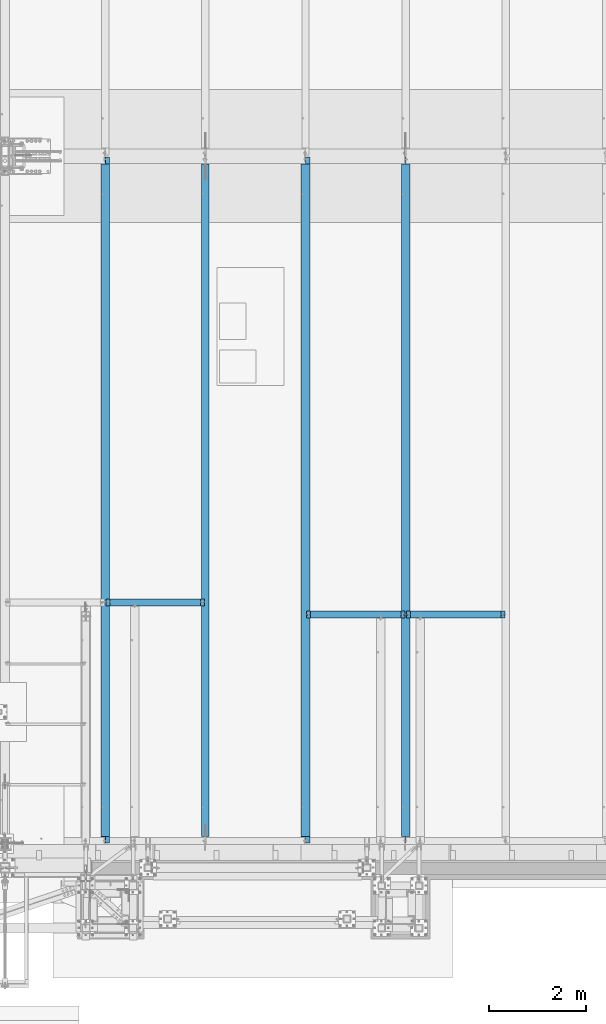
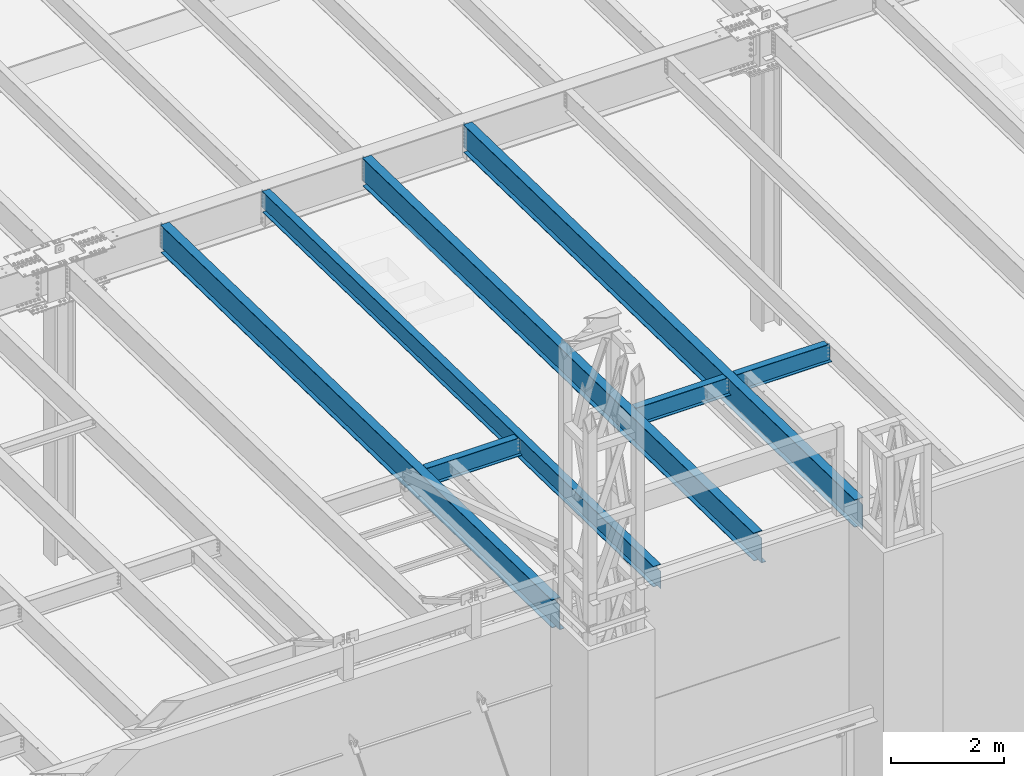
# One storey, part 1066 of 1763: 7 beams, 7 elements without a shape of their own.
"""IFC2X3 building model written with IfcOpenShell, lengths in millimetres."""

import ifcopenshell
import ifcopenshell.guid

model = None  # the IFC model being written
_history = None  # IfcOwnerHistory: only IFC2X3 demands one
_inside = {}  # id of a spatial element -> (the spatial element, [elements in it])
_under = {}  # id of a project, library or spatial element -> (it, [spatial elements below it])
_declared = {}  # id of a project -> (the project, [libraries it declares])
_typed = {}  # id of a type object -> (the type object, [elements of that type])
_made_of = {}  # id of a material, layer set ... -> (it, [elements and type objects made of it])


def new_model(schema):
    """Start an empty IFC model of exactly this schema.

    Asked for "IFC4X3", IfcOpenShell would pick the latest addendum, in which some entities
    have other attributes; the version numbers below select the first issue.
    IFC2X3 requires an IfcOwnerHistory on every rooted entity: one is made here for all.
    """
    global model, _history
    if schema == "IFC4X3":
        model = ifcopenshell.file(schema_version=(4, 3, 0, 0))
    else:
        model = ifcopenshell.file(schema=schema)
    _inside.clear()
    _under.clear()
    _declared.clear()
    _typed.clear()
    _made_of.clear()
    _history = None
    if model.schema == "IFC2X3":
        org = make("IfcOrganization", Name="unknown")
        user = make(
            "IfcPersonAndOrganization",
            ThePerson=make("IfcPerson", FamilyName="unknown"),
            TheOrganization=org,
        )
        app = make(
            "IfcApplication",
            ApplicationDeveloper=org,
            Version="unknown",
            ApplicationFullName="unknown",
            ApplicationIdentifier="unknown",
        )
        _history = make(
            "IfcOwnerHistory",
            OwningUser=user,
            OwningApplication=app,
            ChangeAction="ADDED",
            CreationDate=0,
        )
    return model


def make(cls, **values):
    """One entity of the class cls with the attributes given. An attribute that is None is left unset."""
    return model.create_entity(
        cls, **{name: value for name, value in values.items() if value is not None}
    )


def rooted(cls, **values):
    """An entity with a GlobalId (a new one), such as an element, a storey or a relation."""
    return make(cls, GlobalId=ifcopenshell.guid.new(), OwnerHistory=_history, **values)


def si_unit(unit_type, name, prefix=None):
    """IfcSIUnit, for example si_unit("LENGTHUNIT", "METRE", prefix="MILLI")."""
    return make("IfcSIUnit", UnitType=unit_type, Prefix=prefix, Name=name)


def assignment(units):
    """IfcUnitAssignment: the units of a project."""
    return None if units is None else make("IfcUnitAssignment", Units=units)


def point(xyz):
    """IfcCartesianPoint."""
    return None if xyz is None else make("IfcCartesianPoint", Coordinates=xyz)


def direction(xyz):
    """IfcDirection."""
    return None if xyz is None else make("IfcDirection", DirectionRatios=xyz)


def frame(location, z_axis=None, x_axis=None):
    """IfcAxis2Placement3D, a coordinate frame: its origin and axes. An axis left out is left unset."""
    return make(
        "IfcAxis2Placement3D",
        Location=point(location),
        Axis=direction(z_axis),
        RefDirection=direction(x_axis),
    )


def origin_with_axes():
    """The frame at (0, 0, 0) with the z axis (0, 0, 1) and the x axis (1, 0, 0) written out."""
    return frame((0.0, 0.0, 0.0), z_axis=(0.0, 0.0, 1.0), x_axis=(1.0, 0.0, 0.0))


def place(relative_to, where):
    """IfcLocalPlacement: puts the frame where relative to a parent placement (None: the world)."""
    return make(
        "IfcLocalPlacement", PlacementRelTo=relative_to, RelativePlacement=where
    )


def context(
    kind, dimensions, precision=None, world=None, true_north=None, identifier=None
):
    """IfcGeometricRepresentationContext, for example the 3D "Model" context."""
    return make(
        "IfcGeometricRepresentationContext",
        ContextIdentifier=identifier,
        ContextType=kind,
        CoordinateSpaceDimension=dimensions,
        Precision=precision,
        WorldCoordinateSystem=world,
        TrueNorth=true_north,
    )


def subcontext(parent, identifier, kind, view, scale=None):
    """IfcGeometricRepresentationSubContext, for example "Body" below "Model"."""
    return make(
        "IfcGeometricRepresentationSubContext",
        ContextIdentifier=identifier,
        ContextType=kind,
        ParentContext=parent,
        TargetScale=scale,
        TargetView=view,
    )


def project(units=None, contexts=None):
    """IfcProject with its units and contexts."""
    return rooted(
        "IfcProject",
        Name="project",
        RepresentationContexts=contexts,
        UnitsInContext=assignment(units),
    )


def spatial(cls, under=None, at=None, **own):
    """A site, building, storey or space (cls), placed at a placement, below another one or the project."""
    s = rooted(cls, ObjectPlacement=at, **own)
    if under is not None:
        _under.setdefault(under.id(), (under, []))[1].append(s)
    return s


def faces_of(points, faces, orient=None, outer=None):
    """IfcFace entities. A face is a list of loops; a loop is a list of indices into points, from 0.

    orient and outer hold one flag for each loop. By default every Orientation is true, the
    first loop of a face is its IfcFaceOuterBound and the others are IfcFaceBound.
    """
    made = []
    for i, loops in enumerate(faces):
        bounds = []
        for j, loop in enumerate(loops):
            is_outer = j == 0 if outer is None else outer[i][j]
            bounds.append(
                make(
                    "IfcFaceOuterBound" if is_outer else "IfcFaceBound",
                    Bound=make("IfcPolyLoop", Polygon=[points[k] for k in loop]),
                    Orientation=True if orient is None else orient[i][j],
                )
            )
        made.append(make("IfcFace", Bounds=bounds))
    return made


def faceted_brep(points, faces, orient=None, outer=None, voids=None):
    """IfcFacetedBrep: a solid bounded by flat faces; with voids (closed shells), ...WithVoids."""
    shared = [point(p) for p in points]
    hull = make("IfcClosedShell", CfsFaces=faces_of(shared, faces, orient, outer))
    if voids is None:
        return make("IfcFacetedBrep", Outer=hull)
    return make(
        "IfcFacetedBrepWithVoids",
        Outer=hull,
        Voids=[
            make(cls, CfsFaces=faces_of(shared, fs, o, b)) for cls, fs, o, b in voids
        ],
    )


def shape(context_of_items, identifier, shape_type, items):
    """IfcShapeRepresentation: the items that make up one representation, for example the "Body"."""
    return make(
        "IfcShapeRepresentation",
        ContextOfItems=context_of_items,
        RepresentationIdentifier=identifier,
        RepresentationType=shape_type,
        Items=items,
    )


def material(Name=None, Category=None):
    """IfcMaterial."""
    return make("IfcMaterial", Name=Name, Category=Category)


def made_of(thing, what):
    """Note that an element or type object is made of a material, layer set ...; save() writes the relation."""
    if what is not None:
        _made_of.setdefault(what.id(), (what, []))[1].append(thing)
    return thing


def type_object(cls, material=None, **own):
    """A type object (cls), such as IfcWallType, which elements share."""
    return made_of(rooted(cls, **own), material)


def element(
    cls,
    number,
    at=None,
    inside=None,
    cuts=None,
    type_object=None,
    material=None,
    context=None,
    identifier="Body",
    shape_type=None,
    held_by="IfcProductDefinitionShape",
    body=None,
    shapes=None,
    **own,
):
    """One element of the class cls, such as IfcWall. Its Tag is "e" and its number.

    at: its placement. inside: the storey or other place that contains it. cuts: it is an
    opening in that element (IfcRelVoidsElement). A single representation is given by context,
    identifier, shape_type and body (its items); several are given by shapes. held_by: the class
    of the entity that holds the representations. save() writes the other relations.
    """
    e = rooted(cls, Tag="e%d" % number, ObjectPlacement=at, **own)
    if body is not None:
        shapes = [shape(context, identifier, shape_type, body)]
    if shapes is not None:
        e.Representation = make(held_by, Representations=shapes)
    if inside is not None:
        _inside.setdefault(inside.id(), (inside, []))[1].append(e)
    if cuts is not None:
        rooted(
            "IfcRelVoidsElement", RelatingBuildingElement=cuts, RelatedOpeningElement=e
        )
    if type_object is not None:
        _typed.setdefault(type_object.id(), (type_object, []))[1].append(e)
    return made_of(e, material)


def aggregate(whole, parts):
    """IfcRelAggregates: a whole, such as a stair, and the parts it consists of."""
    return rooted("IfcRelAggregates", RelatingObject=whole, RelatedObjects=parts)


def save(model, path):
    """Write the relations noted so far, then the file.

    IfcRelAggregates (storeys below a building ...), IfcRelContainedInSpatialStructure (elements
    in a storey), IfcRelDefinesByType, IfcRelAssociatesMaterial and IfcRelDeclares: one each for
    every whole, place, type object, material and project.
    """
    for whole, parts in _under.values():
        aggregate(whole, parts)
    for where, things in _inside.values():
        rooted(
            "IfcRelContainedInSpatialStructure",
            RelatedElements=things,
            RelatingStructure=where,
        )
    for kind, things in _typed.values():
        rooted("IfcRelDefinesByType", RelatedObjects=things, RelatingType=kind)
    for what, things in _made_of.values():
        rooted("IfcRelAssociatesMaterial", RelatedObjects=things, RelatingMaterial=what)
    for by, libraries in _declared.values():
        rooted("IfcRelDeclares", RelatingContext=by, RelatedDefinitions=libraries)
    model.write(path)


model = new_model("IFC2X3")

# Units and contexts
model_context = context("Model", 3, precision=1e-05, world=origin_with_axes())
body_context = subcontext(model_context, "Body", "Model", "MODEL_VIEW")
ifc_project = project(units=[si_unit("LENGTHUNIT", "METRE", prefix="MILLI"), si_unit("AREAUNIT", "SQUARE_METRE"), si_unit("VOLUMEUNIT", "CUBIC_METRE"), si_unit("MASSUNIT", "GRAM", prefix="KILO"), si_unit("TIMEUNIT", "SECOND"), si_unit("PLANEANGLEUNIT", "RADIAN"), si_unit("SOLIDANGLEUNIT", "STERADIAN"), si_unit("THERMODYNAMICTEMPERATUREUNIT", "DEGREE_CELSIUS"), si_unit("LUMINOUSINTENSITYUNIT", "LUMEN")], contexts=[model_context])

# Site, building, storey
site_placement = place(None, origin_with_axes())
site = spatial("IfcSite", under=ifc_project, at=site_placement, CompositionType="ELEMENT")
building_placement = place(site_placement, origin_with_axes())
building = spatial("IfcBuilding", under=site, at=building_placement, Name="Undefined", CompositionType="ELEMENT")
storey_placement = place(building_placement, origin_with_axes())
storey = spatial("IfcBuildingStorey", under=building, at=storey_placement, Name="Undefined", CompositionType="ELEMENT", Elevation=0.0)

# Assembly, beam
assembly_1_placement = place(storey_placement, origin_with_axes())
assembly_1 = element("IfcElementAssembly", 1, at=assembly_1_placement, inside=storey, Name="BEAM", AssemblyPlace="NOTDEFINED", PredefinedType="RIGID_FRAME")
ifc_material = material(Name="STEEL/A992")
beam_type_1 = type_object("IfcBeamType", Name="W16X26", PredefinedType="NOTDEFINED")
beam_1_placement = place(assembly_1_placement, frame((-47337.3044138869, -8739.17923577986, 11900.6299693336), z_axis=(0.0, 0.0, 1.0), x_axis=(1.0, 0.0, 0.0)))
beam_1 = element("IfcBeam", 2, at=beam_1_placement, type_object=beam_type_1, material=ifc_material, Name="BEAM", ObjectType="W16X26", context=body_context, shape_type="Brep", body=[
    faceted_brep([(1964.9626759028, -69.8500000000004, 200.025), (1964.9626759028, -69.8500000000004, 190.5), (1964.9626759028, -3.17499999999927, 190.5), (1964.9626759028, -3.17499999999927, 180.715001487531), (1964.9626759028, 3.17499999999927, 180.715001487531), (1964.9626759028, 3.17499999999927, 190.5), (1964.9626759028, 69.8500000000004, 190.5), (1964.9626759028, 69.8500000000004, 200.025), (1965.92940582539, -3.17499999999927, 175.854921969485), (1965.92940582539, 3.17499999999927, 175.854921969485), (1968.68241972587, -3.17499999999927, 171.734745501331), (1968.68241972587, 3.17499999999927, 171.734745501331), (1972.80259619402, -3.17499999999927, 168.981731600854), (1972.80259619402, 3.17499999999927, 168.981731600854), (1977.66267571207, -3.17499999999927, 168.015001678266), (1977.66267571207, 3.17499999999927, 168.015001678266), (2047.51267590281, -3.17499999999927, 168.015001678266), (2047.51267590281, 3.17499999999927, 168.015001678266), (99.5367830456744, -69.8500000000004, 200.025), (99.5367830456744, 69.8500000000004, 200.025), (99.5367830456744, 69.8500000000004, 190.5), (99.5367830456744, 3.17499999999927, 190.5), (99.5367830456744, 3.17499999999927, 180.715001487704), (99.5367830456744, -3.17499999999927, 180.715001487704), (99.5367830456744, -3.17499999999927, 190.5), (99.5367830456744, -69.8500000000004, 190.5), (98.5700531230832, 3.17499999999927, 175.854921969658), (98.5700531230832, -3.17499999999927, 175.854921969658), (95.8170392226093, 3.17499999999927, 171.734745501504), (95.8170392226093, -3.17499999999927, 171.734745501504), (91.6968627544557, 3.17499999999927, 168.981731601027), (91.6968627544557, -3.17499999999927, 168.981731601027), (86.8367832364092, 3.17499999999927, 168.015001678439), (86.8367832364092, -3.17499999999927, 168.015001678439), (16.9867830456715, 3.17499999999927, 168.015001678439), (16.9867830456715, -3.17499999999927, 168.015001678439), (16.9867830456715, 3.17499999999927, -190.5), (16.9867830456715, 69.8500000000004, -190.5), (16.9867830456715, 69.8500000000004, -200.025), (16.9867830456715, -69.8500000000004, -200.025), (16.9867830456715, -69.8500000000004, -190.5), (16.9867830456715, -3.17499999999927, -190.5), (2047.51267590281, 3.17499999999927, -190.5), (2047.51267590281, 69.8500000000004, -190.5), (2047.51267590281, 69.8500000000004, -200.025), (2047.51267590281, -69.8500000000004, -200.025), (2047.51267590281, -69.8500000000004, -190.5), (2047.51267590281, -3.17499999999927, -190.5)], [[[0, 1, 2, 3, 4, 5, 6, 7]], [[8, 9, 4, 3]], [[10, 11, 9, 8]], [[12, 13, 11, 10]], [[14, 15, 13, 12]], [[16, 17, 15, 14]], [[18, 19, 20, 21, 22, 23, 24, 25]], [[23, 22, 26, 27]], [[27, 26, 28, 29]], [[29, 28, 30, 31]], [[31, 30, 32, 33]], [[33, 32, 34, 35]], [[36, 37, 38, 39, 40, 41, 35, 34]], [[37, 36, 42, 43]], [[38, 37, 43, 44]], [[39, 38, 44, 45]], [[40, 39, 45, 46]], [[41, 40, 46, 47]], [[12, 10, 8, 3, 2, 24, 23, 27, 29, 31, 33, 35, 41, 47, 16, 14]], [[25, 24, 2, 1]], [[18, 25, 1, 0]], [[19, 18, 0, 7]], [[20, 19, 7, 6]], [[21, 20, 6, 5]], [[42, 36, 34, 32, 30, 28, 26, 22, 21, 5, 4, 9, 11, 13, 15, 17]], [[47, 46, 45, 44, 43, 42, 17, 16]]]),
])
aggregate(assembly_1, [beam_1])

assembly_2_placement = place(storey_placement, origin_with_axes())
assembly_2 = element("IfcElementAssembly", 3, at=assembly_2_placement, inside=storey, Name="BEAM", AssemblyPlace="NOTDEFINED", PredefinedType="RIGID_FRAME")
beam_2_placement = place(assembly_2_placement, frame((-41143.8087022698, -8991.62546735552, 11908.3665130615), z_axis=(0.0, 0.0, 1.0), x_axis=(1.0, 0.0, 0.0)))
beam_2 = element("IfcBeam", 4, at=beam_2_placement, type_object=beam_type_1, material=ifc_material, Name="BEAM", ObjectType="W16X26", context=body_context, shape_type="Brep", body=[
    faceted_brep([(1965.43839285714, -69.8500000000004, 200.025), (1965.43839285714, -69.8500000000004, 190.5), (1965.43839285714, -3.17499999999927, 190.5), (1965.43839285714, -3.17499999999927, 180.715001487799), (1965.43839285714, 3.17499999999927, 180.715001487799), (1965.43839285714, 3.17499999999927, 190.5), (1965.43839285714, 69.8500000000004, 190.5), (1965.43839285714, 69.8500000000004, 200.025), (1966.40512277973, -3.17499999999927, 175.854921969752), (1966.40512277973, 3.17499999999927, 175.854921969752), (1969.15813668021, -3.17499999999927, 171.734745501599), (1969.15813668021, 3.17499999999927, 171.734745501599), (1973.27831314836, -3.17499999999927, 168.981731601121), (1973.27831314836, 3.17499999999927, 168.981731601121), (1978.13839266641, -3.17499999999927, 168.015001678534), (1978.13839266641, 3.17499999999927, 168.015001678534), (2047.98839285714, -3.17499999999927, 168.015001678534), (2047.98839285714, 3.17499999999927, 168.015001678534), (100.012500000012, -69.8500000000004, 200.025), (100.012500000012, 69.8500000000004, 200.025), (100.012500000012, 69.8500000000004, 190.5), (100.012500000012, 3.17499999999927, 190.5), (100.012500000012, 3.17499999999927, 180.715001488035), (100.012500000012, -3.17499999999927, 180.715001488035), (100.012500000012, -3.17499999999927, 190.5), (100.012500000012, -69.8500000000004, 190.5), (99.0457700774205, 3.17499999999927, 175.854921969989), (99.0457700774205, -3.17499999999927, 175.854921969989), (96.2927561769466, 3.17499999999927, 171.734745501835), (96.2927561769466, -3.17499999999927, 171.734745501835), (92.1725797087929, 3.17499999999927, 168.981731601358), (92.1725797087929, -3.17499999999927, 168.981731601358), (87.3125001907465, 3.17499999999927, 168.01500167877), (87.3125001907465, -3.17499999999927, 168.01500167877), (17.4625000000087, 3.17499999999927, 168.01500167877), (17.4625000000087, -3.17499999999927, 168.01500167877), (17.4625000000087, 3.17499999999927, -190.5), (17.4625000000087, 69.8500000000004, -190.5), (17.4625000000087, 69.8500000000004, -200.025), (17.4625000000087, -69.8500000000004, -200.025), (17.4625000000087, -69.8500000000004, -190.5), (17.4625000000087, -3.17499999999927, -190.5), (2047.98839285714, 3.17499999999927, -190.5), (2047.98839285714, 69.8500000000004, -190.5), (2047.98839285714, 69.8500000000004, -200.025), (2047.98839285714, -69.8500000000004, -200.025), (2047.98839285714, -69.8500000000004, -190.5), (2047.98839285714, -3.17499999999927, -190.5)], [[[0, 1, 2, 3, 4, 5, 6, 7]], [[8, 9, 4, 3]], [[10, 11, 9, 8]], [[12, 13, 11, 10]], [[14, 15, 13, 12]], [[16, 17, 15, 14]], [[18, 19, 20, 21, 22, 23, 24, 25]], [[23, 22, 26, 27]], [[27, 26, 28, 29]], [[29, 28, 30, 31]], [[31, 30, 32, 33]], [[33, 32, 34, 35]], [[36, 37, 38, 39, 40, 41, 35, 34]], [[37, 36, 42, 43]], [[38, 37, 43, 44]], [[39, 38, 44, 45]], [[40, 39, 45, 46]], [[41, 40, 46, 47]], [[12, 10, 8, 3, 2, 24, 23, 27, 29, 31, 33, 35, 41, 47, 16, 14]], [[25, 24, 2, 1]], [[18, 25, 1, 0]], [[19, 18, 0, 7]], [[20, 19, 7, 6]], [[21, 20, 6, 5]], [[42, 36, 34, 32, 30, 28, 26, 22, 21, 5, 4, 9, 11, 13, 15, 17]], [[47, 46, 45, 44, 43, 42, 17, 16]]]),
])
aggregate(assembly_2, [beam_2])

assembly_3_placement = place(storey_placement, origin_with_axes())
assembly_3 = element("IfcElementAssembly", 5, at=assembly_3_placement, inside=storey, Name="BEAM", AssemblyPlace="NOTDEFINED", PredefinedType="RIGID_FRAME")
beam_3_placement = place(assembly_3_placement, frame((-43208.4658451269, -8991.62546735552, 11908.3665130615), z_axis=(0.0, 0.0, 1.0), x_axis=(1.0, 0.0, 0.0)))
beam_3 = element("IfcBeam", 6, at=beam_3_placement, type_object=beam_type_1, material=ifc_material, Name="BEAM", ObjectType="W16X26", context=body_context, shape_type="Brep", body=[
    faceted_brep([(1964.64464285716, -69.8500000000004, 200.025), (1964.64464285716, -69.8500000000004, 190.5), (1964.64464285716, -3.17499999999927, 190.5), (1964.64464285716, -3.17499999999927, 180.715001487766), (1964.64464285716, 3.17499999999927, 180.715001487766), (1964.64464285716, 3.17499999999927, 190.5), (1964.64464285716, 69.8500000000004, 190.5), (1964.64464285716, 69.8500000000004, 200.025), (1965.61137277975, -3.17499999999927, 175.85492196972), (1965.61137277975, 3.17499999999927, 175.85492196972), (1968.36438668022, -3.17499999999927, 171.734745501566), (1968.36438668022, 3.17499999999927, 171.734745501566), (1972.48456314838, -3.17499999999927, 168.981731601089), (1972.48456314838, 3.17499999999927, 168.981731601089), (1977.34464266642, -3.17499999999927, 168.015001678501), (1977.34464266642, 3.17499999999927, 168.015001678501), (2047.19464285716, -3.17499999999927, 168.015001678501), (2047.19464285716, 3.17499999999927, 168.015001678501), (100.012500000012, -69.8500000000004, 200.025), (100.012500000012, 69.8500000000004, 200.025), (100.012500000012, 69.8500000000004, 190.5), (100.012500000012, 3.17499999999927, 190.5), (100.012500000012, 3.17499999999927, 180.715001488035), (100.012500000012, -3.17499999999927, 180.715001488035), (100.012500000012, -3.17499999999927, 190.5), (100.012500000012, -69.8500000000004, 190.5), (99.0457700774205, 3.17499999999927, 175.854921969989), (99.0457700774205, -3.17499999999927, 175.854921969989), (96.2927561769466, 3.17499999999927, 171.734745501835), (96.2927561769466, -3.17499999999927, 171.734745501835), (92.1725797087929, 3.17499999999927, 168.981731601358), (92.1725797087929, -3.17499999999927, 168.981731601358), (87.3125001907465, 3.17499999999927, 168.01500167877), (87.3125001907465, -3.17499999999927, 168.01500167877), (17.4625000000087, 3.17499999999927, 168.01500167877), (17.4625000000087, -3.17499999999927, 168.01500167877), (17.4625000000087, 3.17499999999927, -190.5), (17.4625000000087, 69.8500000000004, -190.5), (17.4625000000087, 69.8500000000004, -200.025), (17.4625000000087, -69.8500000000004, -200.025), (17.4625000000087, -69.8500000000004, -190.5), (17.4625000000087, -3.17499999999927, -190.5), (2047.19464285716, 3.17499999999927, -190.5), (2047.19464285716, 69.8500000000004, -190.5), (2047.19464285716, 69.8500000000004, -200.025), (2047.19464285716, -69.8500000000004, -200.025), (2047.19464285716, -69.8500000000004, -190.5), (2047.19464285716, -3.17499999999927, -190.5)], [[[0, 1, 2, 3, 4, 5, 6, 7]], [[8, 9, 4, 3]], [[10, 11, 9, 8]], [[12, 13, 11, 10]], [[14, 15, 13, 12]], [[16, 17, 15, 14]], [[18, 19, 20, 21, 22, 23, 24, 25]], [[23, 22, 26, 27]], [[27, 26, 28, 29]], [[29, 28, 30, 31]], [[31, 30, 32, 33]], [[33, 32, 34, 35]], [[36, 37, 38, 39, 40, 41, 35, 34]], [[37, 36, 42, 43]], [[38, 37, 43, 44]], [[39, 38, 44, 45]], [[40, 39, 45, 46]], [[41, 40, 46, 47]], [[27, 29, 31, 33, 35, 41, 47, 16, 14, 12, 10, 8, 3, 2, 24, 23]], [[2, 1, 25, 24]], [[1, 0, 18, 25]], [[0, 7, 19, 18]], [[7, 6, 20, 19]], [[6, 5, 21, 20]], [[5, 4, 9, 11, 13, 15, 17, 42, 36, 34, 32, 30, 28, 26, 22, 21]], [[47, 46, 45, 44, 43, 42, 17, 16]]]),
])
aggregate(assembly_3, [beam_3])

assembly_4_placement = place(storey_placement, origin_with_axes())
assembly_4 = element("IfcElementAssembly", 7, at=assembly_4_placement, inside=storey, Name="BEAM", AssemblyPlace="NOTDEFINED", PredefinedType="RIGID_FRAME")
beam_type_2 = type_object("IfcBeamType", Name="W18X35", PredefinedType="NOTDEFINED")
beam_4_placement = place(assembly_4_placement, frame((-45273.1229879841, -13720.7116881753, 11979.324245716), z_axis=(0.0, 0.0209013539966291, 0.999781542838788), x_axis=(0.0, 0.999781542776098, -0.0209013569953182)))
beam_4 = element("IfcBeam", 8, at=beam_4_placement, type_object=beam_type_2, material=ifc_material, Name="BEAM", ObjectType="W18X35", context=body_context, shape_type="Brep", body=[
    faceted_brep([(14013.4742659529, 3.96875815020758, -214.312500004788), (14013.4742659529, 3.96867708732316, -225.425000004796), (14013.4742625578, 76.1999999999971, -225.425000004796), (14013.4742625578, 76.1999999999971, -214.312500004788), (14114.8308465226, 3.96875272147736, -214.31250000482), (14115.0631635925, 3.96935896987998, -225.425000004829), (165.239414196454, -3.96875, -214.312500000224), (165.239414196454, -76.1999999999971, -214.312500000224), (14013.4742635568, -76.1999999999971, -214.312500004788), (14013.4742601621, -3.96875, -214.312500004788), (147.642190818971, 3.96875, 214.312500000126), (147.642190818971, 76.1999999999971, 214.312500000126), (14013.4742637916, 76.1999999999971, 214.312499995558), (14013.4742637916, 3.96875, 214.312499995558), (147.642190818973, -76.1999999999971, 225.425000000136), (147.642190818973, 76.1999999999971, 225.425000000136), (147.64219081896, 3.96871432078478, 180.974999809452), (147.64219081896, -3.96875, 180.974999809452), (147.642190818971, -3.96875, 214.312500000126), (147.642190818971, -76.1999999999971, 214.312500000126), (146.675460896369, 3.96871857677615, 176.114920291397), (146.675460896369, -3.96875, 176.114920291397), (143.922446995883, 3.96872218462522, 171.994743823234), (143.922446995883, -3.96875, 171.994743823234), (139.802270527716, 3.96872459507722, 169.241729922749), (139.802270527716, -3.96875, 169.241729922749), (134.942191009661, 3.96872544115467, 168.275000000162), (134.942191009661, -3.96875, 168.275000000162), (21.8369643202805, 3.96875, 168.275000000198), (21.8369643202805, -3.96875, 168.275000000198), (29.6866157757122, 3.96875, -207.200000000927), (29.6866157757122, -3.96875, -207.200000000927), (153.992191009647, 3.96905148871156, -207.200000000968), (153.992191009647, -3.96875, -207.200000000968), (158.852270527705, 3.96905233643338, -208.166729923558), (158.852270527705, -3.96875, -208.166729923558), (162.972446995866, 3.96905474898085, -210.919743824044), (162.972446995866, -3.96875, -210.919743824044), (165.239414196456, 3.96949987131666, -214.312500000224), (165.239414196456, 76.1999999999971, -214.312500000224), (165.725460896349, 76.1999999999971, -215.039920292209), (165.725460896349, -76.1999999999971, -215.039920292209), (166.692190818938, 76.1999999999971, -219.899999810266), (166.692190818938, -76.1999999999971, -219.899999810266), (166.692190818936, 76.1999999999971, -225.425000000232), (166.692190818938, -76.1999999999971, -225.425000000232), (14013.4742635568, -76.1999999999971, -225.425000004796), (14013.4742601621, -3.96882895631279, -225.425000004796), (14165.6419465735, -3.96875, -214.312500004837), (14165.8742636433, -3.96882179351087, -225.425000004845), (14165.8742636433, 3.96935896987998, -225.425000004845), (14165.6419465735, 3.96875, -214.312500004837), (14165.2105234864, 3.96875, -193.676095376959), (14157.6436017429, 3.96875, 168.274999877091), (14157.6436017429, -3.96875, 168.274999877091), (14165.2105212195, -3.96875, -193.675986946198), (14021.3141840829, -3.96875, 169.241729799678), (14017.1940076147, -3.96875, 171.994743700165), (14014.4409937142, -3.96875, 176.114920168327), (14013.4742637916, -3.96875, 180.974999686383), (14013.4742637916, -3.96875, 214.312499995558), (14026.1742636009, -3.96875, 168.274999877087), (14013.4742637916, -76.1999999999971, 214.312499995558), (14013.4742637916, -76.1999999999971, 225.424999995566), (14013.4742637916, 76.1999999999971, 225.424999995566), (14013.4742637916, 3.96869272583717, 180.974999686383), (14014.4409937142, 3.96869696542853, 176.114920168327), (14017.1940076147, 3.9687005586602, 171.994743700165), (14021.3141840829, 3.9687029584893, 169.241729799678), (14026.1742636009, 3.96870379956817, 168.274999877087)], [[[0, 1, 2, 3]], [[4, 5, 1, 0]], [[6, 7, 8, 9]], [[10, 11, 12, 13]], [[14, 15, 11, 10, 16, 17, 18, 19]], [[17, 16, 20, 21]], [[21, 20, 22, 23]], [[23, 22, 24, 25]], [[25, 24, 26, 27]], [[27, 26, 28, 29]], [[29, 28, 30, 31]], [[31, 30, 32, 33]], [[33, 32, 34, 35]], [[35, 34, 36, 37]], [[7, 6, 37, 36, 38, 39, 40, 41]], [[41, 40, 42, 43]], [[43, 42, 44, 45]], [[7, 41, 43, 45, 46, 8]], [[8, 46, 47, 9]], [[48, 9, 47, 49]], [[50, 51, 52, 53, 54, 55, 48, 49]], [[56, 57, 58, 59, 60, 18, 17, 21, 23, 25, 27, 29, 31, 33, 35, 37, 6, 9, 48, 55, 54, 61]], [[19, 18, 60, 62]], [[14, 19, 62, 63]], [[15, 14, 63, 64]], [[11, 15, 64, 12]], [[63, 62, 60, 59, 65, 13, 12, 64]], [[58, 66, 65, 59]], [[57, 67, 66, 58]], [[56, 68, 67, 57]], [[61, 69, 68, 56]], [[54, 53, 69, 61]], [[52, 51, 4, 0, 38, 36, 34, 32, 30, 28, 26, 24, 22, 20, 16, 10, 13, 65, 66, 67, 68, 69, 53]], [[39, 38, 0, 3]], [[44, 42, 40, 39, 3, 2]], [[50, 49, 47, 46, 45, 44, 2, 1, 5]], [[51, 50, 5, 4]]]),
])
aggregate(assembly_4, [beam_4])

assembly_5_placement = place(storey_placement, origin_with_axes())
assembly_5 = element("IfcElementAssembly", 9, at=assembly_5_placement, inside=storey, Name="BEAM", AssemblyPlace="NOTDEFINED", PredefinedType="RIGID_FRAME")
beam_type_3 = type_object("IfcBeamType", Name="W24X55", PredefinedType="NOTDEFINED")
beam_5_placement = place(assembly_5_placement, frame((-41143.8087022698, -13722.2711313488, 11904.7280453544), z_axis=(0.0, 0.0209013539966291, 0.999781542838788), x_axis=(0.0, 0.999781542776098, -0.0209013569953182)))
beam_5 = element("IfcBeam", 10, at=beam_5_placement, type_object=beam_type_3, material=ifc_material, Name="BEAM", ObjectType="W24X55", context=body_context, shape_type="Brep", body=[
    faceted_brep([(147.642131555314, 4.76249999999709, 287.337500000182), (147.642131555314, 88.9000000000015, 287.337500000182), (14016.5938908944, 88.9000000000015, 287.33749999561), (14016.5938908944, 4.76249999999709, 287.33749999561), (147.642131555318, -88.9000000000015, 300.037500000191), (147.642131555318, 88.9000000000015, 300.037500000191), (147.642131555303, 4.76249999999709, 255.587499809666), (147.642131555303, -4.76249999999709, 255.587499809666), (147.642131555311, -4.76249999999709, 278.45873112723), (147.642131555314, -4.76249999999709, 287.337500000182), (147.642131555314, -88.9000000000015, 287.337500000182), (146.675401632712, 4.76249999999709, 250.727420291609), (146.675401632712, -4.76249999999709, 250.727420291609), (143.922387732226, 4.76249999999709, 246.607243823446), (143.922387732226, -4.76249999999709, 246.607243823446), (139.802211264063, 4.76249999999709, 243.854229922961), (139.802211264063, -4.76249999999709, 243.854229922961), (134.942131746006, 4.76249999999709, 242.887500000372), (134.942131746006, -4.76249999999709, 242.887500000372), (21.8369050565634, 4.76249999999709, 242.88750000041), (21.8369050565634, -4.76249999999709, 242.88750000041), (164.712538750962, -88.9000000000015, -287.337500000285), (164.978043973639, -88.9000000000015, -300.037500000297), (14016.5938907292, -88.9000000000015, -300.037500004861), (14016.5938907292, -88.9000000000015, -287.337500004849), (164.712538750964, -4.76249999999709, -287.337500000285), (14016.5938879523, -4.76249999999709, -287.337500004849), (164.978043973639, -4.76200008391606, -300.037500000297), (32.9217481032374, -4.76249999999709, -287.337500000243), (33.187253325912, -4.76200008391606, -300.037500000251), (32.9217481032374, 4.76249999999709, -287.337500000243), (33.187253325912, 4.76299991607812, -300.037500000251), (164.712538750964, 4.76249999999709, -287.337500000285), (164.978043973639, 4.76299991607812, -300.037500000297), (164.712538750962, 88.9000000000015, -287.337500000285), (164.978043973639, 88.9000000000015, -300.037500000297), (14168.993890746, 4.76299991607812, -300.03750000491), (14118.1827906951, 4.76299991607812, -300.037500004893), (14117.9172854725, 4.76249999999709, -287.337500004882), (14168.7283855234, 4.76249999999709, -287.3375000049), (14016.593893803, 4.76238284193096, -300.037500004859), (14016.593893803, 4.76249999999709, -287.337500004851), (14168.993890746, -4.7626181790838, -300.03750000491), (14118.1827906952, -4.76261985585734, -300.037500004893), (14016.5938879524, -4.76262320829846, -300.037500004861), (14016.5938910267, 88.9000000000015, -300.037500004861), (14168.7283855234, -4.76249999999709, -287.3375000049), (14117.9172854725, -4.76249999999709, -287.337500004882), (14168.3301647496, 4.76249999999709, -268.289272721053), (14157.6435424792, 4.76249999999709, 242.887499877306), (14157.6435424792, -4.76249999999709, 242.887499877306), (14168.3301609801, -4.76249999999709, -268.289092414178), (14029.2938907037, -4.76249999999709, 242.887499877303), (14024.4338111857, -4.76249999999709, 243.854229799896), (14020.3136347175, -4.76249999999709, 246.607243700379), (14017.560620817, -4.76249999999709, 250.727420168543), (14016.5938908944, -4.76249999999709, 255.5874996866), (14016.5938908944, -4.76249999999709, 287.33749999561), (14106.8324424283, -4.76249999999709, 242.887499877304), (14016.5938908944, -88.9000000000015, 287.33749999561), (14016.5938908944, -88.9000000000015, 300.037499995622), (14016.5938908944, 88.9000000000015, 300.037499995622), (14016.5938908944, 4.76249999999709, 255.5874996866), (14017.560620817, 4.76249999999709, 250.727420168543), (14020.3136347175, 4.76249999999709, 246.607243700379), (14024.4338111857, 4.76249999999709, 243.854229799896), (14029.2938907037, 4.76249999999709, 242.887499877303), (14016.5938910267, 88.9000000000015, -287.337500004851)], [[[0, 1, 2, 3]], [[4, 5, 1, 0, 6, 7, 8, 9, 10]], [[7, 6, 11, 12]], [[12, 11, 13, 14]], [[14, 13, 15, 16]], [[16, 15, 17, 18]], [[18, 17, 19, 20]], [[21, 22, 23, 24]], [[25, 21, 24, 26]], [[22, 21, 25, 27]], [[27, 25, 28, 29]], [[20, 19, 30, 31, 29, 28]], [[31, 30, 32, 33]], [[33, 32, 34, 35]], [[36, 37, 38, 39]], [[37, 40, 41, 38]], [[36, 42, 43, 44, 23, 22, 27, 29, 31, 33, 35, 45, 40, 37]], [[24, 23, 44, 26]], [[43, 42, 46, 47, 26, 44]], [[36, 39, 48, 49, 50, 51, 46, 42]], [[52, 53, 54, 55, 56, 57, 9, 8, 7, 12, 14, 16, 18, 20, 28, 25, 26, 47, 46, 51, 50, 58]], [[10, 9, 57, 59]], [[4, 10, 59, 60]], [[5, 4, 60, 61]], [[1, 5, 61, 2]], [[60, 59, 57, 56, 62, 3, 2, 61]], [[55, 63, 62, 56]], [[54, 64, 63, 55]], [[53, 65, 64, 54]], [[52, 66, 65, 53]], [[58, 50, 49, 66, 52]], [[48, 39, 38, 41, 32, 30, 19, 17, 15, 13, 11, 6, 0, 3, 62, 63, 64, 65, 66, 49]], [[34, 32, 41, 67]], [[35, 34, 67, 45]], [[41, 40, 45, 67]]]),
])
aggregate(assembly_5, [beam_5])

assembly_6_placement = place(storey_placement, origin_with_axes())
assembly_6 = element("IfcElementAssembly", 11, at=assembly_6_placement, inside=storey, Name="BEAM", AssemblyPlace="NOTDEFINED", PredefinedType="RIGID_FRAME")
beam_6_placement = place(assembly_6_placement, frame((-43208.4658451269, -13722.271131349, 11904.7280453544), z_axis=(0.0, 0.0209013539966291, 0.999781542838788), x_axis=(0.0, 0.999781542776098, -0.0209013569953182)))
beam_6 = element("IfcBeam", 12, at=beam_6_placement, type_object=beam_type_3, material=ifc_material, Name="BEAM", ObjectType="W24X55", context=body_context, shape_type="Brep", body=[
    faceted_brep([(14016.6713189086, 5.06262333965424, -287.337500004851), (14016.6713189087, 5.06237371335737, -300.037500004863), (14016.6713136267, 88.9000000000015, -300.037500004863), (14016.6713136267, 88.9000000000015, -287.337500004851), (14168.9938907462, 5.06238331007626, -300.03750000491), (14168.7283855236, 5.06263291966025, -287.3375000049), (153.914692441238, 4.76249999999709, 287.33750000018), (153.914692441238, 88.9000000000015, 287.33750000018), (14016.6713298856, 88.9000000000015, 287.33749999561), (14016.6713298856, 4.76249999999709, 287.33749999561), (153.914692441242, -88.9000000000015, 300.03750000019), (153.914692441242, 88.9000000000015, 300.03750000019), (153.914692441229, 4.76249999999709, 255.327497673446), (153.914692441229, -4.76249999999709, 255.327497673446), (153.914692441238, -4.76249999999709, 287.33750000018), (153.914692441238, -88.9000000000015, 287.33750000018), (152.947962518636, 4.76249999999709, 250.467418155387), (152.947962518636, -4.76249999999709, 250.467418155387), (150.194948618151, 4.76249999999709, 246.347241687226), (150.194948618151, -4.76249999999709, 246.347241687226), (146.074772149987, 4.76249999999709, 243.594227786743), (146.074772149987, -4.76249999999709, 243.594227786743), (141.214692631929, 4.76249999999709, 242.627497864154), (141.214692631929, -4.76249999999709, 242.627497864154), (21.8423406414186, 4.76249999999709, 242.627497864194), (21.8423406414186, -4.76249999999709, 242.627497864194), (32.9217481032374, -4.76249999999709, -287.337500000243), (32.9217481034411, -88.9000000000015, -287.337500000243), (14168.7283855236, -88.9000000000015, -287.3375000049), (14168.7283855234, -4.76249999999709, -287.3375000049), (14024.5112501769, -4.76249999999709, 243.594227663818), (14020.3910737087, -4.76249999999709, 246.347241564303), (14017.6380598082, -4.76249999999709, 250.467418032464), (14016.6713298856, -4.76249999999709, 255.327497550523), (14016.6713298856, -4.76249999999709, 287.33749999561), (14157.648978064, -4.76249999999709, 242.627497741229), (14029.3713296949, -4.76249999999709, 242.627497741227), (14016.6713298856, -88.9000000000015, 287.33749999561), (14016.6713298856, -88.9000000000015, 300.03749999562), (14016.6713298856, 88.9000000000015, 300.03749999562), (14016.6713298856, 4.76249999999709, 255.327497550523), (14017.6380598082, 4.76249999999709, 250.467418032464), (14020.3910737087, 4.76249999999709, 246.347241564303), (14024.5112501769, 4.76249999999709, 243.594227663818), (14029.3713296949, 4.76249999999709, 242.627497741227), (14157.648978064, 4.76249999999709, 242.627497741229), (14168.7283855234, 4.76249999999709, -287.3375000049), (32.9217481032374, 4.76249999999709, -287.337500000243), (153.914693154151, 88.9000000000015, -287.337500000283), (153.914693154147, 88.9000000000015, -300.037500000291), (153.914705143417, 5.06262326784054, -300.037500000293), (153.91470514345, 5.06237364542176, -287.337500000283), (33.1872533261158, 5.06260600377573, -300.037500000253), (32.9217481034411, 5.06235634340555, -287.337500000243), (33.1872533261158, -88.9000000000015, -300.037500000253), (14168.9938907462, -88.9000000000015, -300.03750000491)], [[[0, 1, 2, 3]], [[4, 1, 0, 5]], [[6, 7, 8, 9]], [[10, 11, 7, 6, 12, 13, 14, 15]], [[13, 12, 16, 17]], [[17, 16, 18, 19]], [[19, 18, 20, 21]], [[21, 20, 22, 23]], [[23, 22, 24, 25]], [[26, 27, 28, 29]], [[30, 31, 32, 33, 34, 14, 13, 17, 19, 21, 23, 25, 26, 29, 35, 36]], [[15, 14, 34, 37]], [[10, 15, 37, 38]], [[11, 10, 38, 39]], [[7, 11, 39, 8]], [[38, 37, 34, 33, 40, 9, 8, 39]], [[32, 41, 40, 33]], [[31, 42, 41, 32]], [[30, 43, 42, 31]], [[36, 44, 43, 30]], [[35, 45, 44, 36]], [[46, 47, 24, 22, 20, 18, 16, 12, 6, 9, 40, 41, 42, 43, 44, 45]], [[48, 49, 50, 51]], [[51, 50, 52, 53]], [[54, 27, 26, 25, 24, 47, 53, 52]], [[27, 54, 55, 28]], [[46, 45, 35, 29, 28, 55, 4, 5]], [[3, 48, 51, 53, 47, 46, 5, 0]], [[49, 48, 3, 2]], [[55, 54, 52, 50, 49, 2, 1, 4]]]),
])
aggregate(assembly_6, [beam_6])

assembly_7_placement = place(storey_placement, origin_with_axes())
assembly_7 = element("IfcElementAssembly", 13, at=assembly_7_placement, inside=storey, Name="BEAM", AssemblyPlace="NOTDEFINED", PredefinedType="RIGID_FRAME")
beam_7_placement = place(assembly_7_placement, frame((-47337.7801308412, -13722.2711313488, 11904.7280453544), z_axis=(0.0, 0.0209013539966291, 0.999781542838788), x_axis=(0.0, 0.999781542776098, -0.0209013569953182)))
beam_7 = element("IfcBeam", 14, at=beam_7_placement, type_object=beam_type_3, material=ifc_material, Name="BEAM", ObjectType="W24X55", context=body_context, shape_type="Brep", body=[
    faceted_brep([(14016.6713189086, 5.06262333965424, -287.337500004851), (14016.6713189087, 5.06237371335737, -300.037500004863), (14016.6713136267, 88.9000000000015, -300.037500004863), (14016.6713136267, 88.9000000000015, -287.337500004851), (14168.9938907462, 5.06238331007626, -300.03750000491), (14168.7283855236, 5.06263291966025, -287.3375000049), (153.914692441238, 4.76249999999709, 287.33750000018), (153.914692441238, 88.9000000000015, 287.33750000018), (14016.6713298856, 88.9000000000015, 287.33749999561), (14016.6713298856, 4.76249999999709, 287.33749999561), (153.914692441242, -88.9000000000015, 300.03750000019), (153.914692441242, 88.9000000000015, 300.03750000019), (153.914692441229, 4.76249999999709, 255.327497673446), (153.914692441229, -4.76249999999709, 255.327497673446), (153.914692441238, -4.76249999999709, 287.33750000018), (153.914692441238, -88.9000000000015, 287.33750000018), (152.947962518636, 4.76249999999709, 250.467418155387), (152.947962518636, -4.76249999999709, 250.467418155387), (150.194948618151, 4.76249999999709, 246.347241687226), (150.194948618151, -4.76249999999709, 246.347241687226), (146.074772149987, 4.76249999999709, 243.594227786743), (146.074772149987, -4.76249999999709, 243.594227786743), (141.214692631929, 4.76249999999709, 242.627497864154), (141.214692631929, -4.76249999999709, 242.627497864154), (21.8423406414186, 4.76249999999709, 242.627497864194), (21.8423406414186, -4.76249999999709, 242.627497864194), (32.9217481032374, -4.76249999999709, -287.337500000243), (32.9217481034411, -88.9000000000015, -287.337500000243), (14168.7283855236, -88.9000000000015, -287.3375000049), (14168.7283855234, -4.76249999999709, -287.3375000049), (14024.5112501769, -4.76249999999709, 243.594227663818), (14020.3910737087, -4.76249999999709, 246.347241564303), (14017.6380598082, -4.76249999999709, 250.467418032464), (14016.6713298856, -4.76249999999709, 255.327497550523), (14016.6713298856, -4.76249999999709, 287.33749999561), (14157.648978064, -4.76249999999709, 242.627497741229), (14029.3713296949, -4.76249999999709, 242.627497741227), (14016.6713298856, -88.9000000000015, 287.33749999561), (14016.6713298856, -88.9000000000015, 300.03749999562), (14016.6713298856, 88.9000000000015, 300.03749999562), (14016.6713298856, 4.76249999999709, 255.327497550523), (14017.6380598082, 4.76249999999709, 250.467418032464), (14020.3910737087, 4.76249999999709, 246.347241564303), (14024.5112501769, 4.76249999999709, 243.594227663818), (14029.3713296949, 4.76249999999709, 242.627497741227), (14157.648978064, 4.76249999999709, 242.627497741229), (14168.7283855234, 4.76249999999709, -287.3375000049), (32.9217481032374, 4.76249999999709, -287.337500000243), (153.914693154151, 88.9000000000015, -287.337500000283), (153.914693154147, 88.9000000000015, -300.037500000291), (153.914705143417, 5.06262326784054, -300.037500000293), (153.91470514345, 5.06237364542176, -287.337500000283), (33.1872533261158, 5.06260600377573, -300.037500000253), (32.9217481034411, 5.06235634340555, -287.337500000243), (33.1872533261158, -88.9000000000015, -300.037500000253), (14168.9938907462, -88.9000000000015, -300.03750000491)], [[[0, 1, 2, 3]], [[4, 1, 0, 5]], [[6, 7, 8, 9]], [[10, 11, 7, 6, 12, 13, 14, 15]], [[13, 12, 16, 17]], [[17, 16, 18, 19]], [[19, 18, 20, 21]], [[21, 20, 22, 23]], [[23, 22, 24, 25]], [[26, 27, 28, 29]], [[30, 31, 32, 33, 34, 14, 13, 17, 19, 21, 23, 25, 26, 29, 35, 36]], [[15, 14, 34, 37]], [[10, 15, 37, 38]], [[11, 10, 38, 39]], [[7, 11, 39, 8]], [[38, 37, 34, 33, 40, 9, 8, 39]], [[32, 41, 40, 33]], [[31, 42, 41, 32]], [[30, 43, 42, 31]], [[36, 44, 43, 30]], [[35, 45, 44, 36]], [[46, 47, 24, 22, 20, 18, 16, 12, 6, 9, 40, 41, 42, 43, 44, 45]], [[48, 49, 50, 51]], [[51, 50, 52, 53]], [[54, 27, 26, 25, 24, 47, 53, 52]], [[27, 54, 55, 28]], [[46, 45, 35, 29, 28, 55, 4, 5]], [[3, 48, 51, 53, 47, 46, 5, 0]], [[49, 48, 3, 2]], [[55, 54, 52, 50, 49, 2, 1, 4]]]),
])
aggregate(assembly_7, [beam_7])

save(model, "model.ifc")
